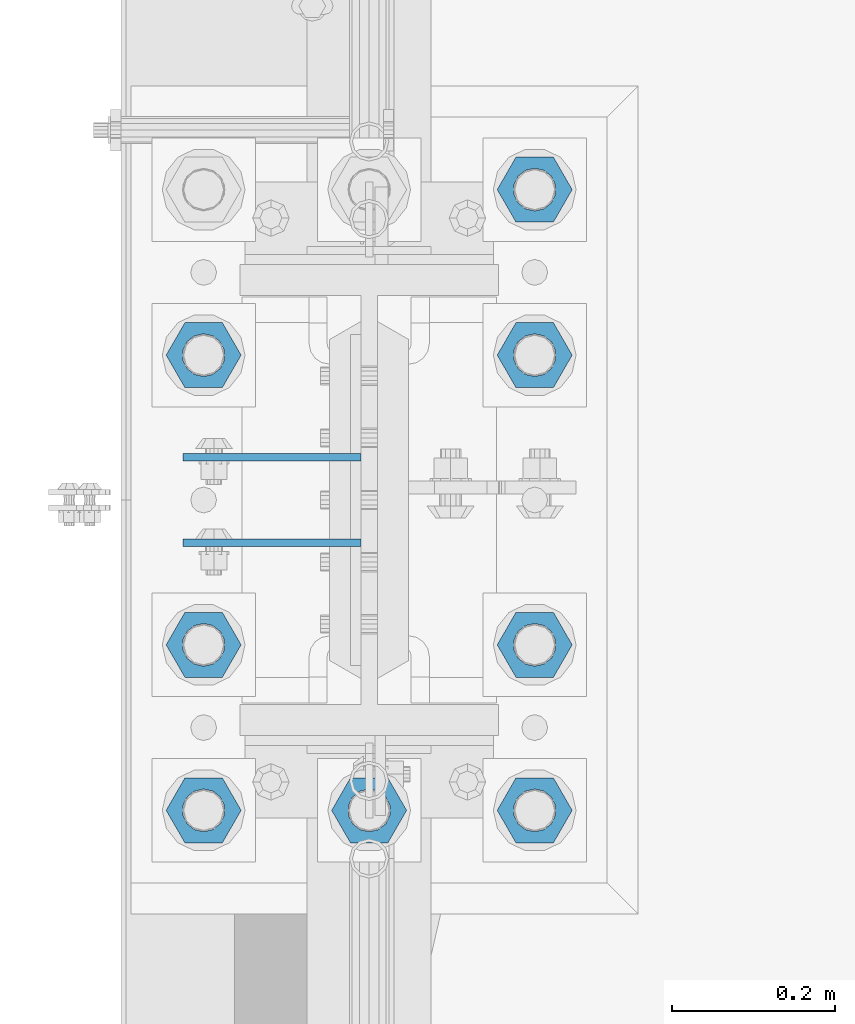
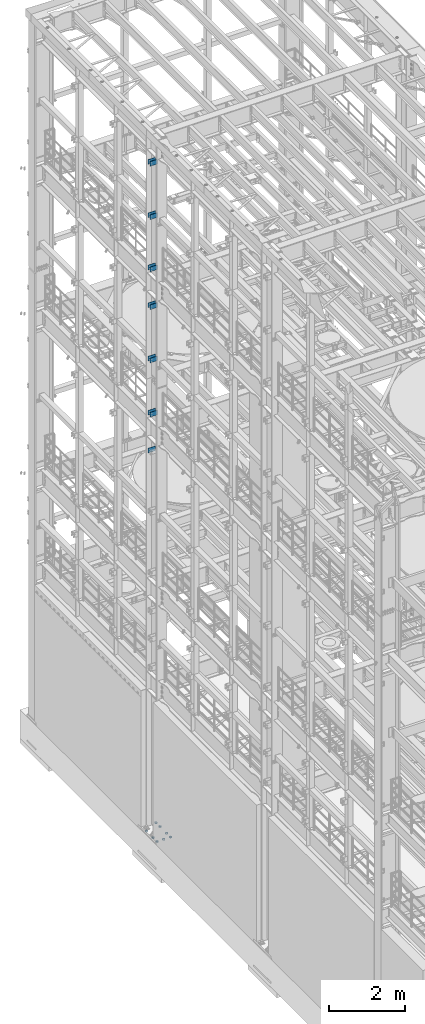
# One storey, part 1287 of 1876: 21 beams, 3 elements without a shape of their own.
"""IFC2X3 building model written with IfcOpenShell, lengths in millimetres."""

from ifc_helpers import new_model, si_unit, frame, origin_with_axes, place, context, subcontext, project, spatial, faceted_brep, material, type_object, element, aggregate, save


model = new_model("IFC2X3")

# Units and contexts
model_context = context("Model", 3, precision=1e-05, world=origin_with_axes())
body_context = subcontext(model_context, "Body", "Model", "MODEL_VIEW")
ifc_project = project(units=[si_unit("LENGTHUNIT", "METRE", prefix="MILLI"), si_unit("AREAUNIT", "SQUARE_METRE"), si_unit("VOLUMEUNIT", "CUBIC_METRE"), si_unit("MASSUNIT", "GRAM", prefix="KILO"), si_unit("TIMEUNIT", "SECOND"), si_unit("PLANEANGLEUNIT", "RADIAN"), si_unit("SOLIDANGLEUNIT", "STERADIAN"), si_unit("THERMODYNAMICTEMPERATUREUNIT", "DEGREE_CELSIUS"), si_unit("LUMINOUSINTENSITYUNIT", "LUMEN")], contexts=[model_context])

# Site, building, storey
site_placement = place(None, origin_with_axes())
site = spatial("IfcSite", under=ifc_project, at=site_placement, CompositionType="ELEMENT")
building_placement = place(site_placement, origin_with_axes())
building = spatial("IfcBuilding", under=site, at=building_placement, Name="Undefined", CompositionType="ELEMENT")
storey_placement = place(building_placement, origin_with_axes())
storey = spatial("IfcBuildingStorey", under=building, at=storey_placement, Name="Undefined", CompositionType="ELEMENT", Elevation=0.0)

# Assembly, beams
assembly_1_placement = place(storey_placement, origin_with_axes())
assembly_1 = element("IfcElementAssembly", 1, at=assembly_1_placement, inside=storey, Name="COLUMN", AssemblyPlace="NOTDEFINED", PredefinedType="RIGID_FRAME")
ifc_material_1 = material(Name="STEEL/A36")
beam_type_1 = type_object("IfcBeamType", PredefinedType="NOTDEFINED")
beam_1_placement = place(assembly_1_placement, frame((-10.31875, 7672.38750076294, 21678.9), z_axis=(0.0, 0.0, -1.0), x_axis=(-1.0, 0.0, 0.0)))
beam_1 = element("IfcBeam", 2, at=beam_1_placement, type_object=beam_type_1, material=ifc_material_1, Name="PLATE", context=body_context, shape_type="Brep", body=[
    faceted_brep([(0.0, 4.76249999999982, -76.1999999999998), (3.63797880709171e-12, 4.76249999999982, 76.1999969482422), (218.28125, 4.76250000000005, 76.2000000000007), (218.28125, 4.76250000000005, -76.2000000000007), (3.63797880709171e-12, -4.76249999999982, 76.1999969482422), (218.28125, -4.76250000000005, 76.2000000000007), (0.0, -4.76249999999982, -76.1999999999998), (218.28125, -4.76250000000005, -76.2000000000007)], [[[0, 1, 2, 3]], [[1, 4, 5, 2]], [[4, 6, 7, 5]], [[6, 0, 3, 7]], [[5, 7, 3, 2]], [[6, 4, 1, 0]]]),
])
beam_2_placement = place(assembly_1_placement, frame((-10.31875, 7567.61250076294, 21678.9), z_axis=(0.0, 0.0, -1.0), x_axis=(-1.0, 0.0, 0.0)))
beam_2 = element("IfcBeam", 3, at=beam_2_placement, type_object=beam_type_1, material=ifc_material_1, Name="PLATE", context=body_context, shape_type="Brep", body=[
    faceted_brep([(0.0, 4.76249999999982, -76.1999999999998), (3.63797880709171e-12, 4.76249999999982, 76.1999969482422), (218.28125, 4.76250000000005, 76.2000000000007), (218.28125, 4.76250000000005, -76.2000000000007), (3.63797880709171e-12, -4.76249999999982, 76.1999969482422), (218.28125, -4.76250000000005, 76.2000000000007), (0.0, -4.76249999999982, -76.1999999999998), (218.28125, -4.76250000000005, -76.2000000000007)], [[[0, 1, 2, 3]], [[1, 4, 5, 2]], [[4, 6, 7, 5]], [[6, 0, 3, 7]], [[5, 7, 3, 2]], [[6, 4, 1, 0]]]),
])
beam_3_placement = place(assembly_1_placement, frame((-10.31875, 7672.38750076294, 19958.05), z_axis=(0.0, 0.0, -1.0), x_axis=(-1.0, 0.0, 0.0)))
beam_3 = element("IfcBeam", 4, at=beam_3_placement, type_object=beam_type_1, material=ifc_material_1, Name="PLATE", context=body_context, shape_type="Brep", body=[
    faceted_brep([(0.0, 4.76249999999982, -76.1999999999998), (3.63797880709171e-12, 4.76249999999982, 76.1999969482422), (218.28125, 4.76250000000005, 76.2000000000007), (218.28125, 4.76250000000005, -76.2000000000007), (3.63797880709171e-12, -4.76249999999982, 76.1999969482422), (218.28125, -4.76250000000005, 76.2000000000007), (0.0, -4.76249999999982, -76.1999999999998), (218.28125, -4.76250000000005, -76.2000000000007)], [[[0, 1, 2, 3]], [[1, 4, 5, 2]], [[4, 6, 7, 5]], [[6, 0, 3, 7]], [[5, 7, 3, 2]], [[6, 4, 1, 0]]]),
])
beam_4_placement = place(assembly_1_placement, frame((-10.31875, 7567.61250076294, 19958.05), z_axis=(0.0, 0.0, -1.0), x_axis=(-1.0, 0.0, 0.0)))
beam_4 = element("IfcBeam", 5, at=beam_4_placement, type_object=beam_type_1, material=ifc_material_1, Name="PLATE", context=body_context, shape_type="Brep", body=[
    faceted_brep([(0.0, 4.76249999999982, -76.1999999999998), (3.63797880709171e-12, 4.76249999999982, 76.1999969482422), (218.28125, 4.76250000000005, 76.2000000000007), (218.28125, 4.76250000000005, -76.2000000000007), (3.63797880709171e-12, -4.76249999999982, 76.1999969482422), (218.28125, -4.76250000000005, 76.2000000000007), (0.0, -4.76249999999982, -76.1999999999998), (218.28125, -4.76250000000005, -76.2000000000007)], [[[0, 1, 2, 3]], [[1, 4, 5, 2]], [[4, 6, 7, 5]], [[6, 0, 3, 7]], [[5, 7, 3, 2]], [[6, 4, 1, 0]]]),
])
beam_5_placement = place(assembly_1_placement, frame((-10.31875, 7672.38750076294, 18275.3), z_axis=(0.0, 0.0, -1.0), x_axis=(-1.0, 0.0, 0.0)))
beam_5 = element("IfcBeam", 6, at=beam_5_placement, type_object=beam_type_1, material=ifc_material_1, Name="PLATE", context=body_context, shape_type="Brep", body=[
    faceted_brep([(0.0, 4.76249999999982, -76.1999999999998), (3.63797880709171e-12, 4.76249999999982, 76.1999969482422), (218.28125, 4.76250000000005, 76.2000000000007), (218.28125, 4.76250000000005, -76.2000000000007), (3.63797880709171e-12, -4.76249999999982, 76.1999969482422), (218.28125, -4.76250000000005, 76.2000000000007), (0.0, -4.76249999999982, -76.1999999999998), (218.28125, -4.76250000000005, -76.2000000000007)], [[[0, 1, 2, 3]], [[1, 4, 5, 2]], [[4, 6, 7, 5]], [[6, 0, 3, 7]], [[5, 7, 3, 2]], [[6, 4, 1, 0]]]),
])
beam_6_placement = place(assembly_1_placement, frame((-10.31875, 7567.61250076294, 18275.3), z_axis=(0.0, 0.0, -1.0), x_axis=(-1.0, 0.0, 0.0)))
beam_6 = element("IfcBeam", 7, at=beam_6_placement, type_object=beam_type_1, material=ifc_material_1, Name="PLATE", context=body_context, shape_type="Brep", body=[
    faceted_brep([(0.0, 4.76249999999982, -76.1999999999998), (3.63797880709171e-12, 4.76249999999982, 76.1999969482422), (218.28125, 4.76250000000005, 76.2000000000007), (218.28125, 4.76250000000005, -76.2000000000007), (3.63797880709171e-12, -4.76249999999982, 76.1999969482422), (218.28125, -4.76250000000005, 76.2000000000007), (0.0, -4.76249999999982, -76.1999999999998), (218.28125, -4.76250000000005, -76.2000000000007)], [[[0, 1, 2, 3]], [[1, 4, 5, 2]], [[4, 6, 7, 5]], [[6, 0, 3, 7]], [[5, 7, 3, 2]], [[6, 4, 1, 0]]]),
])
beam_7_placement = place(assembly_1_placement, frame((-10.31875, 7672.38750076294, 17056.1), z_axis=(0.0, 0.0, -1.0), x_axis=(-1.0, 0.0, 0.0)))
beam_7 = element("IfcBeam", 8, at=beam_7_placement, type_object=beam_type_1, material=ifc_material_1, Name="PLATE", context=body_context, shape_type="Brep", body=[
    faceted_brep([(0.0, 4.76249999999982, -76.1999999999998), (3.63797880709171e-12, 4.76249999999982, 76.1999969482422), (218.28125, 4.76250000000005, 76.2000000000007), (218.28125, 4.76250000000005, -76.2000000000007), (3.63797880709171e-12, -4.76249999999982, 76.1999969482422), (218.28125, -4.76250000000005, 76.2000000000007), (0.0, -4.76249999999982, -76.1999999999998), (218.28125, -4.76250000000005, -76.2000000000007)], [[[0, 1, 2, 3]], [[1, 4, 5, 2]], [[4, 6, 7, 5]], [[6, 0, 3, 7]], [[5, 7, 3, 2]], [[6, 4, 1, 0]]]),
])
beam_8_placement = place(assembly_1_placement, frame((-10.31875, 7567.61250076294, 17056.1), z_axis=(0.0, 0.0, -1.0), x_axis=(-1.0, 0.0, 0.0)))
beam_8 = element("IfcBeam", 9, at=beam_8_placement, type_object=beam_type_1, material=ifc_material_1, Name="PLATE", context=body_context, shape_type="Brep", body=[
    faceted_brep([(0.0, 4.76249999999982, -76.1999999999998), (3.63797880709171e-12, 4.76249999999982, 76.1999969482422), (218.28125, 4.76250000000005, 76.2000000000007), (218.28125, 4.76250000000005, -76.2000000000007), (3.63797880709171e-12, -4.76249999999982, 76.1999969482422), (218.28125, -4.76250000000005, 76.2000000000007), (0.0, -4.76249999999982, -76.1999999999998), (218.28125, -4.76250000000005, -76.2000000000007)], [[[0, 1, 2, 3]], [[1, 4, 5, 2]], [[4, 6, 7, 5]], [[6, 0, 3, 7]], [[5, 7, 3, 2]], [[6, 4, 1, 0]]]),
])
beam_9_placement = place(assembly_1_placement, frame((-10.31875, 7672.38750076294, 15335.25), z_axis=(0.0, 0.0, -1.0), x_axis=(-1.0, 0.0, 0.0)))
beam_9 = element("IfcBeam", 10, at=beam_9_placement, type_object=beam_type_1, material=ifc_material_1, Name="PLATE", context=body_context, shape_type="Brep", body=[
    faceted_brep([(0.0, 4.76249999999982, -76.1999999999998), (3.63797880709171e-12, 4.76249999999982, 76.1999969482422), (218.28125, 4.76250000000005, 76.2000000000007), (218.28125, 4.76250000000005, -76.2000000000007), (3.63797880709171e-12, -4.76249999999982, 76.1999969482422), (218.28125, -4.76250000000005, 76.2000000000007), (0.0, -4.76249999999982, -76.1999999999998), (218.28125, -4.76250000000005, -76.2000000000007)], [[[0, 1, 2, 3]], [[1, 4, 5, 2]], [[4, 6, 7, 5]], [[6, 0, 3, 7]], [[5, 7, 3, 2]], [[6, 4, 1, 0]]]),
])
beam_10_placement = place(assembly_1_placement, frame((-10.31875, 7567.61250076294, 15335.25), z_axis=(0.0, 0.0, -1.0), x_axis=(-1.0, 0.0, 0.0)))
beam_10 = element("IfcBeam", 11, at=beam_10_placement, type_object=beam_type_1, material=ifc_material_1, Name="PLATE", context=body_context, shape_type="Brep", body=[
    faceted_brep([(0.0, 4.76249999999982, -76.1999999999998), (3.63797880709171e-12, 4.76249999999982, 76.1999969482422), (218.28125, 4.76250000000005, 76.2000000000007), (218.28125, 4.76250000000005, -76.2000000000007), (3.63797880709171e-12, -4.76249999999982, 76.1999969482422), (218.28125, -4.76250000000005, 76.2000000000007), (0.0, -4.76249999999982, -76.1999999999998), (218.28125, -4.76250000000005, -76.2000000000007)], [[[0, 1, 2, 3]], [[1, 4, 5, 2]], [[4, 6, 7, 5]], [[6, 0, 3, 7]], [[5, 7, 3, 2]], [[6, 4, 1, 0]]]),
])
aggregate(assembly_1, [beam_1, beam_2, beam_3, beam_4, beam_5, beam_6, beam_7, beam_8, beam_9, beam_10])

assembly_2_placement = place(storey_placement, origin_with_axes())
assembly_2 = element("IfcElementAssembly", 12, at=assembly_2_placement, inside=storey, Name="COLUMN", AssemblyPlace="NOTDEFINED", PredefinedType="RIGID_FRAME")
beam_11_placement = place(assembly_2_placement, frame((-10.31875, 7672.38750076294, 13589.0), z_axis=(0.0, 0.0, -1.0), x_axis=(-1.0, 0.0, 0.0)))
beam_11 = element("IfcBeam", 13, at=beam_11_placement, type_object=beam_type_1, material=ifc_material_1, Name="PLATE", context=body_context, shape_type="Brep", body=[
    faceted_brep([(0.0, 4.76249999999982, -76.1999999999998), (3.63797880709171e-12, 4.76249999999982, 76.1999969482422), (218.28125, 4.76250000000005, 76.2000000000007), (218.28125, 4.76250000000005, -76.2000000000007), (3.63797880709171e-12, -4.76249999999982, 76.1999969482422), (218.28125, -4.76250000000005, 76.2000000000007), (0.0, -4.76249999999982, -76.1999999999998), (218.28125, -4.76250000000005, -76.2000000000007)], [[[0, 1, 2, 3]], [[1, 4, 5, 2]], [[4, 6, 7, 5]], [[6, 0, 3, 7]], [[5, 7, 3, 2]], [[6, 4, 1, 0]]]),
])
beam_12_placement = place(assembly_2_placement, frame((-10.31875, 7567.61250076294, 13589.0), z_axis=(0.0, 0.0, -1.0), x_axis=(-1.0, 0.0, 0.0)))
beam_12 = element("IfcBeam", 14, at=beam_12_placement, type_object=beam_type_1, material=ifc_material_1, Name="PLATE", context=body_context, shape_type="Brep", body=[
    faceted_brep([(0.0, 4.76249999999982, -76.1999999999998), (3.63797880709171e-12, 4.76249999999982, 76.1999969482422), (218.28125, 4.76250000000005, 76.2000000000007), (218.28125, 4.76250000000005, -76.2000000000007), (3.63797880709171e-12, -4.76249999999982, 76.1999969482422), (218.28125, -4.76250000000005, 76.2000000000007), (0.0, -4.76249999999982, -76.1999999999998), (218.28125, -4.76250000000005, -76.2000000000007)], [[[0, 1, 2, 3]], [[1, 4, 5, 2]], [[4, 6, 7, 5]], [[6, 0, 3, 7]], [[5, 7, 3, 2]], [[6, 4, 1, 0]]]),
])
beam_13_placement = place(assembly_2_placement, frame((-10.31875, 7672.38750076294, 12369.8), z_axis=(0.0, 0.0, -1.0), x_axis=(-1.0, 0.0, 0.0)))
beam_13 = element("IfcBeam", 15, at=beam_13_placement, type_object=beam_type_1, material=ifc_material_1, Name="PLATE", context=body_context, shape_type="Brep", body=[
    faceted_brep([(0.0, 4.76249999999982, -76.1999999999998), (3.63797880709171e-12, 4.76249999999982, 76.1999969482422), (218.28125, 4.76250000000005, 76.2000000000007), (218.28125, 4.76250000000005, -76.2000000000007), (3.63797880709171e-12, -4.76249999999982, 76.1999969482422), (218.28125, -4.76250000000005, 76.2000000000007), (0.0, -4.76249999999982, -76.1999999999998), (218.28125, -4.76250000000005, -76.2000000000007)], [[[0, 1, 2, 3]], [[1, 4, 5, 2]], [[4, 6, 7, 5]], [[6, 0, 3, 7]], [[5, 7, 3, 2]], [[6, 4, 1, 0]]]),
])
aggregate(assembly_2, [beam_11, beam_12, beam_13])

assembly_3_placement = place(storey_placement, origin_with_axes())
assembly_3 = element("IfcElementAssembly", 16, at=assembly_3_placement, inside=storey, Name="TEMPLATE", AssemblyPlace="NOTDEFINED", PredefinedType="RIGID_FRAME")
ifc_material_2 = material(Name="STEEL/A563")
beam_type_2 = type_object("IfcBeamType", Name="2_DIA. HALF_NUT", PredefinedType="NOTDEFINED")
beam_14_placement = place(assembly_3_placement, frame((-203.2, 7797.79999847412, 33.3375), z_axis=(0.0, -1.0, 0.0), x_axis=(0.0, 0.0, -1.0)))
beam_14 = element("IfcBeam", 17, at=beam_14_placement, type_object=beam_type_2, material=ifc_material_2, Name="NUT", ObjectType="2_DIA. HALF_NUT", context=body_context, shape_type="Brep", body=[
    faceted_brep([(0.0, -46.0369987487793, 9.09494701772928e-13), (0.0, -23.0184993743896, -39.869213104248), (25.4, -23.0184993743896, -39.869213104248), (25.4, -46.0369987487793, 9.09494701772928e-13), (0.0, 23.0184993743896, -39.869213104248), (25.4, 23.0184993743896, -39.869213104248), (0.0, 46.0369987487793, -9.09494701772928e-13), (25.4, 46.0369987487793, -9.09494701772928e-13), (0.0, 23.0184993743896, 39.869213104248), (25.4, 23.0184993743896, 39.869213104248), (0.0, -23.0184993743896, 39.869213104248), (25.4, -23.0184993743896, 39.869213104248), (0.0, 0.0, 26.1940002441406), (0.0, 11.3650617044514, 23.5999013092769), (25.4, 11.3650617044514, 23.5999013092769), (25.4, 0.0, 26.1940002441406), (0.0, 20.4791109456437, 16.3316083006703), (25.4, 20.4791109456437, 16.3316083006703), (0.0, 25.5370200498346, 5.82867859874477), (25.4, 25.5370200498346, 5.82867859874477), (0.0, 25.5370200498346, -5.82867859874477), (25.4, 25.5370200498346, -5.82867859874477), (0.0, 20.4791109456437, -16.3316083006703), (25.4, 20.4791109456437, -16.3316083006703), (0.0, 11.3650617044514, -23.5999013092769), (25.4, 11.3650617044514, -23.5999013092769), (0.0, 0.0, -26.1940002441406), (25.4, 0.0, -26.1940002441406), (0.0, -11.3650617044514, -23.5999013092769), (25.4, -11.3650617044514, -23.5999013092769), (0.0, -20.4791109456437, -16.3316083006703), (25.4, -20.4791109456437, -16.3316083006703), (0.0, -25.5370200498346, -5.82867859874477), (25.4, -25.5370200498346, -5.82867859874477), (0.0, -25.5370200498346, 5.82867859874477), (25.4, -25.5370200498346, 5.82867859874477), (0.0, -20.4791109456437, 16.3316083006703), (25.4, -20.4791109456437, 16.3316083006703), (0.0, -11.3650617044514, 23.5999013092769), (25.4, -11.3650617044514, 23.5999013092769)], [[[0, 1, 2, 3]], [[1, 4, 5, 2]], [[4, 6, 7, 5]], [[6, 8, 9, 7]], [[8, 10, 11, 9]], [[10, 0, 3, 11]], [[12, 13, 14, 15]], [[13, 16, 17, 14]], [[16, 18, 19, 17]], [[18, 20, 21, 19]], [[20, 22, 23, 21]], [[22, 24, 25, 23]], [[24, 26, 27, 25]], [[26, 28, 29, 27]], [[28, 30, 31, 29]], [[30, 32, 33, 31]], [[32, 34, 35, 33]], [[34, 36, 37, 35]], [[36, 38, 39, 37]], [[38, 12, 15, 39]], [[5, 7, 9, 11, 3, 2], [17, 19, 21, 23, 25, 27, 29, 31, 33, 35, 37, 39, 15, 14]], [[10, 8, 6, 4, 1, 0], [38, 36, 34, 32, 30, 28, 26, 24, 22, 20, 18, 16, 13, 12]]]),
])
beam_15_placement = place(assembly_3_placement, frame((203.2, 8001.00000152588, 33.3375), z_axis=(0.0, 1.0, 0.0), x_axis=(0.0, 0.0, -1.0)))
beam_15 = element("IfcBeam", 18, at=beam_15_placement, type_object=beam_type_2, material=ifc_material_2, Name="NUT", ObjectType="2_DIA. HALF_NUT", context=body_context, shape_type="Brep", body=[
    faceted_brep([(0.0, -46.0369987487793, 9.09494701772928e-13), (0.0, -23.0184993743896, -39.869213104248), (25.4, -23.0184993743896, -39.869213104248), (25.4, -46.0369987487793, 9.09494701772928e-13), (0.0, 23.0184993743896, -39.869213104248), (25.4, 23.0184993743896, -39.869213104248), (0.0, 46.0369987487793, -9.09494701772928e-13), (25.4, 46.0369987487793, -9.09494701772928e-13), (0.0, 23.0184993743896, 39.869213104248), (25.4, 23.0184993743896, 39.869213104248), (0.0, -23.0184993743896, 39.869213104248), (25.4, -23.0184993743896, 39.869213104248), (0.0, 0.0, 26.1940002441406), (0.0, 11.3650617044514, 23.5999013092769), (25.4, 11.3650617044514, 23.5999013092769), (25.4, 0.0, 26.1940002441406), (0.0, 20.4791109456437, 16.3316083006703), (25.4, 20.4791109456437, 16.3316083006703), (0.0, 25.5370200498346, 5.82867859874477), (25.4, 25.5370200498346, 5.82867859874477), (0.0, 25.5370200498346, -5.82867859874477), (25.4, 25.5370200498346, -5.82867859874477), (0.0, 20.4791109456437, -16.3316083006703), (25.4, 20.4791109456437, -16.3316083006703), (0.0, 11.3650617044514, -23.5999013092769), (25.4, 11.3650617044514, -23.5999013092769), (0.0, 0.0, -26.1940002441406), (25.4, 0.0, -26.1940002441406), (0.0, -11.3650617044514, -23.5999013092769), (25.4, -11.3650617044514, -23.5999013092769), (0.0, -20.4791109456437, -16.3316083006703), (25.4, -20.4791109456437, -16.3316083006703), (0.0, -25.5370200498346, -5.82867859874477), (25.4, -25.5370200498346, -5.82867859874477), (0.0, -25.5370200498346, 5.82867859874477), (25.4, -25.5370200498346, 5.82867859874477), (0.0, -20.4791109456437, 16.3316083006703), (25.4, -20.4791109456437, 16.3316083006703), (0.0, -11.3650617044514, 23.5999013092769), (25.4, -11.3650617044514, 23.5999013092769)], [[[0, 1, 2, 3]], [[1, 4, 5, 2]], [[4, 6, 7, 5]], [[6, 8, 9, 7]], [[8, 10, 11, 9]], [[10, 0, 3, 11]], [[12, 13, 14, 15]], [[13, 16, 17, 14]], [[16, 18, 19, 17]], [[18, 20, 21, 19]], [[20, 22, 23, 21]], [[22, 24, 25, 23]], [[24, 26, 27, 25]], [[26, 28, 29, 27]], [[28, 30, 31, 29]], [[30, 32, 33, 31]], [[32, 34, 35, 33]], [[34, 36, 37, 35]], [[36, 38, 39, 37]], [[38, 12, 15, 39]], [[5, 7, 9, 11, 3, 2], [17, 19, 21, 23, 25, 27, 29, 31, 33, 35, 37, 39, 15, 14]], [[10, 8, 6, 4, 1, 0], [38, 36, 34, 32, 30, 28, 26, 24, 22, 20, 18, 16, 13, 12]]]),
])
beam_16_placement = place(assembly_3_placement, frame((203.2, 7797.80000152588, 33.3375), z_axis=(0.0, 1.0, 0.0), x_axis=(0.0, 0.0, -1.0)))
beam_16 = element("IfcBeam", 19, at=beam_16_placement, type_object=beam_type_2, material=ifc_material_2, Name="NUT", ObjectType="2_DIA. HALF_NUT", context=body_context, shape_type="Brep", body=[
    faceted_brep([(0.0, -46.0369987487793, 9.09494701772928e-13), (0.0, -23.0184993743896, -39.869213104248), (25.4, -23.0184993743896, -39.869213104248), (25.4, -46.0369987487793, 9.09494701772928e-13), (0.0, 23.0184993743896, -39.869213104248), (25.4, 23.0184993743896, -39.869213104248), (0.0, 46.0369987487793, -9.09494701772928e-13), (25.4, 46.0369987487793, -9.09494701772928e-13), (0.0, 23.0184993743896, 39.869213104248), (25.4, 23.0184993743896, 39.869213104248), (0.0, -23.0184993743896, 39.869213104248), (25.4, -23.0184993743896, 39.869213104248), (0.0, 0.0, 26.1940002441406), (0.0, 11.3650617044514, 23.5999013092769), (25.4, 11.3650617044514, 23.5999013092769), (25.4, 0.0, 26.1940002441406), (0.0, 20.4791109456437, 16.3316083006703), (25.4, 20.4791109456437, 16.3316083006703), (0.0, 25.5370200498346, 5.82867859874477), (25.4, 25.5370200498346, 5.82867859874477), (0.0, 25.5370200498346, -5.82867859874477), (25.4, 25.5370200498346, -5.82867859874477), (0.0, 20.4791109456437, -16.3316083006703), (25.4, 20.4791109456437, -16.3316083006703), (0.0, 11.3650617044514, -23.5999013092769), (25.4, 11.3650617044514, -23.5999013092769), (0.0, 0.0, -26.1940002441406), (25.4, 0.0, -26.1940002441406), (0.0, -11.3650617044514, -23.5999013092769), (25.4, -11.3650617044514, -23.5999013092769), (0.0, -20.4791109456437, -16.3316083006703), (25.4, -20.4791109456437, -16.3316083006703), (0.0, -25.5370200498346, -5.82867859874477), (25.4, -25.5370200498346, -5.82867859874477), (0.0, -25.5370200498346, 5.82867859874477), (25.4, -25.5370200498346, 5.82867859874477), (0.0, -20.4791109456437, 16.3316083006703), (25.4, -20.4791109456437, 16.3316083006703), (0.0, -11.3650617044514, 23.5999013092769), (25.4, -11.3650617044514, 23.5999013092769)], [[[0, 1, 2, 3]], [[1, 4, 5, 2]], [[4, 6, 7, 5]], [[6, 8, 9, 7]], [[8, 10, 11, 9]], [[10, 0, 3, 11]], [[12, 13, 14, 15]], [[13, 16, 17, 14]], [[16, 18, 19, 17]], [[18, 20, 21, 19]], [[20, 22, 23, 21]], [[22, 24, 25, 23]], [[24, 26, 27, 25]], [[26, 28, 29, 27]], [[28, 30, 31, 29]], [[30, 32, 33, 31]], [[32, 34, 35, 33]], [[34, 36, 37, 35]], [[36, 38, 39, 37]], [[38, 12, 15, 39]], [[5, 7, 9, 11, 3, 2], [17, 19, 21, 23, 25, 27, 29, 31, 33, 35, 37, 39, 15, 14]], [[10, 8, 6, 4, 1, 0], [38, 36, 34, 32, 30, 28, 26, 24, 22, 20, 18, 16, 13, 12]]]),
])
beam_17_placement = place(assembly_3_placement, frame((-203.2, 7442.19999847412, 33.3375), z_axis=(0.0, -1.0, 0.0), x_axis=(0.0, 0.0, -1.0)))
beam_17 = element("IfcBeam", 20, at=beam_17_placement, type_object=beam_type_2, material=ifc_material_2, Name="NUT", ObjectType="2_DIA. HALF_NUT", context=body_context, shape_type="Brep", body=[
    faceted_brep([(0.0, -46.0369987487793, 9.09494701772928e-13), (0.0, -23.0184993743896, -39.869213104248), (25.4, -23.0184993743896, -39.869213104248), (25.4, -46.0369987487793, 9.09494701772928e-13), (0.0, 23.0184993743896, -39.869213104248), (25.4, 23.0184993743896, -39.869213104248), (0.0, 46.0369987487793, -9.09494701772928e-13), (25.4, 46.0369987487793, -9.09494701772928e-13), (0.0, 23.0184993743896, 39.869213104248), (25.4, 23.0184993743896, 39.869213104248), (0.0, -23.0184993743896, 39.869213104248), (25.4, -23.0184993743896, 39.869213104248), (0.0, 0.0, 26.1940002441406), (0.0, 11.3650617044514, 23.5999013092769), (25.4, 11.3650617044514, 23.5999013092769), (25.4, 0.0, 26.1940002441406), (0.0, 20.4791109456437, 16.3316083006703), (25.4, 20.4791109456437, 16.3316083006703), (0.0, 25.5370200498346, 5.82867859874477), (25.4, 25.5370200498346, 5.82867859874477), (0.0, 25.5370200498346, -5.82867859874477), (25.4, 25.5370200498346, -5.82867859874477), (0.0, 20.4791109456437, -16.3316083006703), (25.4, 20.4791109456437, -16.3316083006703), (0.0, 11.3650617044514, -23.5999013092769), (25.4, 11.3650617044514, -23.5999013092769), (0.0, 0.0, -26.1940002441406), (25.4, 0.0, -26.1940002441406), (0.0, -11.3650617044514, -23.5999013092769), (25.4, -11.3650617044514, -23.5999013092769), (0.0, -20.4791109456437, -16.3316083006703), (25.4, -20.4791109456437, -16.3316083006703), (0.0, -25.5370200498346, -5.82867859874477), (25.4, -25.5370200498346, -5.82867859874477), (0.0, -25.5370200498346, 5.82867859874477), (25.4, -25.5370200498346, 5.82867859874477), (0.0, -20.4791109456437, 16.3316083006703), (25.4, -20.4791109456437, 16.3316083006703), (0.0, -11.3650617044514, 23.5999013092769), (25.4, -11.3650617044514, 23.5999013092769)], [[[0, 1, 2, 3]], [[1, 4, 5, 2]], [[4, 6, 7, 5]], [[6, 8, 9, 7]], [[8, 10, 11, 9]], [[10, 0, 3, 11]], [[12, 13, 14, 15]], [[13, 16, 17, 14]], [[16, 18, 19, 17]], [[18, 20, 21, 19]], [[20, 22, 23, 21]], [[22, 24, 25, 23]], [[24, 26, 27, 25]], [[26, 28, 29, 27]], [[28, 30, 31, 29]], [[30, 32, 33, 31]], [[32, 34, 35, 33]], [[34, 36, 37, 35]], [[36, 38, 39, 37]], [[38, 12, 15, 39]], [[5, 7, 9, 11, 3, 2], [17, 19, 21, 23, 25, 27, 29, 31, 33, 35, 37, 39, 15, 14]], [[10, 8, 6, 4, 1, 0], [38, 36, 34, 32, 30, 28, 26, 24, 22, 20, 18, 16, 13, 12]]]),
])
beam_18_placement = place(assembly_3_placement, frame((203.2, 7442.20000152588, 33.3375), z_axis=(0.0, 1.0, 0.0), x_axis=(0.0, 0.0, -1.0)))
beam_18 = element("IfcBeam", 21, at=beam_18_placement, type_object=beam_type_2, material=ifc_material_2, Name="NUT", ObjectType="2_DIA. HALF_NUT", context=body_context, shape_type="Brep", body=[
    faceted_brep([(0.0, -46.0369987487793, 9.09494701772928e-13), (0.0, -23.0184993743896, -39.869213104248), (25.4, -23.0184993743896, -39.869213104248), (25.4, -46.0369987487793, 9.09494701772928e-13), (0.0, 23.0184993743896, -39.869213104248), (25.4, 23.0184993743896, -39.869213104248), (0.0, 46.0369987487793, -9.09494701772928e-13), (25.4, 46.0369987487793, -9.09494701772928e-13), (0.0, 23.0184993743896, 39.869213104248), (25.4, 23.0184993743896, 39.869213104248), (0.0, -23.0184993743896, 39.869213104248), (25.4, -23.0184993743896, 39.869213104248), (0.0, 0.0, 26.1940002441406), (0.0, 11.3650617044514, 23.5999013092769), (25.4, 11.3650617044514, 23.5999013092769), (25.4, 0.0, 26.1940002441406), (0.0, 20.4791109456437, 16.3316083006703), (25.4, 20.4791109456437, 16.3316083006703), (0.0, 25.5370200498346, 5.82867859874477), (25.4, 25.5370200498346, 5.82867859874477), (0.0, 25.5370200498346, -5.82867859874477), (25.4, 25.5370200498346, -5.82867859874477), (0.0, 20.4791109456437, -16.3316083006703), (25.4, 20.4791109456437, -16.3316083006703), (0.0, 11.3650617044514, -23.5999013092769), (25.4, 11.3650617044514, -23.5999013092769), (0.0, 0.0, -26.1940002441406), (25.4, 0.0, -26.1940002441406), (0.0, -11.3650617044514, -23.5999013092769), (25.4, -11.3650617044514, -23.5999013092769), (0.0, -20.4791109456437, -16.3316083006703), (25.4, -20.4791109456437, -16.3316083006703), (0.0, -25.5370200498346, -5.82867859874477), (25.4, -25.5370200498346, -5.82867859874477), (0.0, -25.5370200498346, 5.82867859874477), (25.4, -25.5370200498346, 5.82867859874477), (0.0, -20.4791109456437, 16.3316083006703), (25.4, -20.4791109456437, 16.3316083006703), (0.0, -11.3650617044514, 23.5999013092769), (25.4, -11.3650617044514, 23.5999013092769)], [[[0, 1, 2, 3]], [[1, 4, 5, 2]], [[4, 6, 7, 5]], [[6, 8, 9, 7]], [[8, 10, 11, 9]], [[10, 0, 3, 11]], [[12, 13, 14, 15]], [[13, 16, 17, 14]], [[16, 18, 19, 17]], [[18, 20, 21, 19]], [[20, 22, 23, 21]], [[22, 24, 25, 23]], [[24, 26, 27, 25]], [[26, 28, 29, 27]], [[28, 30, 31, 29]], [[30, 32, 33, 31]], [[32, 34, 35, 33]], [[34, 36, 37, 35]], [[36, 38, 39, 37]], [[38, 12, 15, 39]], [[5, 7, 9, 11, 3, 2], [17, 19, 21, 23, 25, 27, 29, 31, 33, 35, 37, 39, 15, 14]], [[10, 8, 6, 4, 1, 0], [38, 36, 34, 32, 30, 28, 26, 24, 22, 20, 18, 16, 13, 12]]]),
])
beam_19_placement = place(assembly_3_placement, frame((203.2, 7239.00000152588, 33.3375), z_axis=(0.0, 1.0, 0.0), x_axis=(0.0, 0.0, -1.0)))
beam_19 = element("IfcBeam", 22, at=beam_19_placement, type_object=beam_type_2, material=ifc_material_2, Name="NUT", ObjectType="2_DIA. HALF_NUT", context=body_context, shape_type="Brep", body=[
    faceted_brep([(0.0, -46.0369987487793, 9.09494701772928e-13), (0.0, -23.0184993743896, -39.869213104248), (25.4, -23.0184993743896, -39.869213104248), (25.4, -46.0369987487793, 9.09494701772928e-13), (0.0, 23.0184993743896, -39.869213104248), (25.4, 23.0184993743896, -39.869213104248), (0.0, 46.0369987487793, -9.09494701772928e-13), (25.4, 46.0369987487793, -9.09494701772928e-13), (0.0, 23.0184993743896, 39.869213104248), (25.4, 23.0184993743896, 39.869213104248), (0.0, -23.0184993743896, 39.869213104248), (25.4, -23.0184993743896, 39.869213104248), (0.0, 0.0, 26.1940002441406), (0.0, 11.3650617044514, 23.5999013092769), (25.4, 11.3650617044514, 23.5999013092769), (25.4, 0.0, 26.1940002441406), (0.0, 20.4791109456437, 16.3316083006703), (25.4, 20.4791109456437, 16.3316083006703), (0.0, 25.5370200498346, 5.82867859874477), (25.4, 25.5370200498346, 5.82867859874477), (0.0, 25.5370200498346, -5.82867859874477), (25.4, 25.5370200498346, -5.82867859874477), (0.0, 20.4791109456437, -16.3316083006703), (25.4, 20.4791109456437, -16.3316083006703), (0.0, 11.3650617044514, -23.5999013092769), (25.4, 11.3650617044514, -23.5999013092769), (0.0, 0.0, -26.1940002441406), (25.4, 0.0, -26.1940002441406), (0.0, -11.3650617044514, -23.5999013092769), (25.4, -11.3650617044514, -23.5999013092769), (0.0, -20.4791109456437, -16.3316083006703), (25.4, -20.4791109456437, -16.3316083006703), (0.0, -25.5370200498346, -5.82867859874477), (25.4, -25.5370200498346, -5.82867859874477), (0.0, -25.5370200498346, 5.82867859874477), (25.4, -25.5370200498346, 5.82867859874477), (0.0, -20.4791109456437, 16.3316083006703), (25.4, -20.4791109456437, 16.3316083006703), (0.0, -11.3650617044514, 23.5999013092769), (25.4, -11.3650617044514, 23.5999013092769)], [[[0, 1, 2, 3]], [[1, 4, 5, 2]], [[4, 6, 7, 5]], [[6, 8, 9, 7]], [[8, 10, 11, 9]], [[10, 0, 3, 11]], [[12, 13, 14, 15]], [[13, 16, 17, 14]], [[16, 18, 19, 17]], [[18, 20, 21, 19]], [[20, 22, 23, 21]], [[22, 24, 25, 23]], [[24, 26, 27, 25]], [[26, 28, 29, 27]], [[28, 30, 31, 29]], [[30, 32, 33, 31]], [[32, 34, 35, 33]], [[34, 36, 37, 35]], [[36, 38, 39, 37]], [[38, 12, 15, 39]], [[5, 7, 9, 11, 3, 2], [17, 19, 21, 23, 25, 27, 29, 31, 33, 35, 37, 39, 15, 14]], [[10, 8, 6, 4, 1, 0], [38, 36, 34, 32, 30, 28, 26, 24, 22, 20, 18, 16, 13, 12]]]),
])
beam_20_placement = place(assembly_3_placement, frame((0.0, 7238.99999847412, 33.3375), z_axis=(0.0, -1.0, 0.0), x_axis=(0.0, 0.0, -1.0)))
beam_20 = element("IfcBeam", 23, at=beam_20_placement, type_object=beam_type_2, material=ifc_material_2, Name="NUT", ObjectType="2_DIA. HALF_NUT", context=body_context, shape_type="Brep", body=[
    faceted_brep([(0.0, -46.0369987487793, 9.09494701772928e-13), (0.0, -23.0184993743896, -39.869213104248), (25.4, -23.0184993743896, -39.869213104248), (25.4, -46.0369987487793, 9.09494701772928e-13), (0.0, 23.0184993743896, -39.869213104248), (25.4, 23.0184993743896, -39.869213104248), (0.0, 46.0369987487793, -9.09494701772928e-13), (25.4, 46.0369987487793, -9.09494701772928e-13), (0.0, 23.0184993743896, 39.869213104248), (25.4, 23.0184993743896, 39.869213104248), (0.0, -23.0184993743896, 39.869213104248), (25.4, -23.0184993743896, 39.869213104248), (0.0, 0.0, 26.1940002441406), (0.0, 11.3650617044514, 23.5999013092769), (25.4, 11.3650617044514, 23.5999013092769), (25.4, 0.0, 26.1940002441406), (0.0, 20.4791109456437, 16.3316083006703), (25.4, 20.4791109456437, 16.3316083006703), (0.0, 25.5370200498346, 5.82867859874477), (25.4, 25.5370200498346, 5.82867859874477), (0.0, 25.5370200498346, -5.82867859874477), (25.4, 25.5370200498346, -5.82867859874477), (0.0, 20.4791109456437, -16.3316083006703), (25.4, 20.4791109456437, -16.3316083006703), (0.0, 11.3650617044514, -23.5999013092769), (25.4, 11.3650617044514, -23.5999013092769), (0.0, 0.0, -26.1940002441406), (25.4, 0.0, -26.1940002441406), (0.0, -11.3650617044514, -23.5999013092769), (25.4, -11.3650617044514, -23.5999013092769), (0.0, -20.4791109456437, -16.3316083006703), (25.4, -20.4791109456437, -16.3316083006703), (0.0, -25.5370200498346, -5.82867859874477), (25.4, -25.5370200498346, -5.82867859874477), (0.0, -25.5370200498346, 5.82867859874477), (25.4, -25.5370200498346, 5.82867859874477), (0.0, -20.4791109456437, 16.3316083006703), (25.4, -20.4791109456437, 16.3316083006703), (0.0, -11.3650617044514, 23.5999013092769), (25.4, -11.3650617044514, 23.5999013092769)], [[[0, 1, 2, 3]], [[1, 4, 5, 2]], [[4, 6, 7, 5]], [[6, 8, 9, 7]], [[8, 10, 11, 9]], [[10, 0, 3, 11]], [[12, 13, 14, 15]], [[13, 16, 17, 14]], [[16, 18, 19, 17]], [[18, 20, 21, 19]], [[20, 22, 23, 21]], [[22, 24, 25, 23]], [[24, 26, 27, 25]], [[26, 28, 29, 27]], [[28, 30, 31, 29]], [[30, 32, 33, 31]], [[32, 34, 35, 33]], [[34, 36, 37, 35]], [[36, 38, 39, 37]], [[38, 12, 15, 39]], [[5, 7, 9, 11, 3, 2], [17, 19, 21, 23, 25, 27, 29, 31, 33, 35, 37, 39, 15, 14]], [[10, 8, 6, 4, 1, 0], [38, 36, 34, 32, 30, 28, 26, 24, 22, 20, 18, 16, 13, 12]]]),
])
beam_21_placement = place(assembly_3_placement, frame((-203.2, 7238.99999847412, 33.3375), z_axis=(0.0, -1.0, 0.0), x_axis=(0.0, 0.0, -1.0)))
beam_21 = element("IfcBeam", 24, at=beam_21_placement, type_object=beam_type_2, material=ifc_material_2, Name="NUT", ObjectType="2_DIA. HALF_NUT", context=body_context, shape_type="Brep", body=[
    faceted_brep([(0.0, -46.0369987487793, 9.09494701772928e-13), (0.0, -23.0184993743896, -39.869213104248), (25.4, -23.0184993743896, -39.869213104248), (25.4, -46.0369987487793, 9.09494701772928e-13), (0.0, 23.0184993743896, -39.869213104248), (25.4, 23.0184993743896, -39.869213104248), (0.0, 46.0369987487793, -9.09494701772928e-13), (25.4, 46.0369987487793, -9.09494701772928e-13), (0.0, 23.0184993743896, 39.869213104248), (25.4, 23.0184993743896, 39.869213104248), (0.0, -23.0184993743896, 39.869213104248), (25.4, -23.0184993743896, 39.869213104248), (0.0, 0.0, 26.1940002441406), (0.0, 11.3650617044514, 23.5999013092769), (25.4, 11.3650617044514, 23.5999013092769), (25.4, 0.0, 26.1940002441406), (0.0, 20.4791109456437, 16.3316083006703), (25.4, 20.4791109456437, 16.3316083006703), (0.0, 25.5370200498346, 5.82867859874477), (25.4, 25.5370200498346, 5.82867859874477), (0.0, 25.5370200498346, -5.82867859874477), (25.4, 25.5370200498346, -5.82867859874477), (0.0, 20.4791109456437, -16.3316083006703), (25.4, 20.4791109456437, -16.3316083006703), (0.0, 11.3650617044514, -23.5999013092769), (25.4, 11.3650617044514, -23.5999013092769), (0.0, 0.0, -26.1940002441406), (25.4, 0.0, -26.1940002441406), (0.0, -11.3650617044514, -23.5999013092769), (25.4, -11.3650617044514, -23.5999013092769), (0.0, -20.4791109456437, -16.3316083006703), (25.4, -20.4791109456437, -16.3316083006703), (0.0, -25.5370200498346, -5.82867859874477), (25.4, -25.5370200498346, -5.82867859874477), (0.0, -25.5370200498346, 5.82867859874477), (25.4, -25.5370200498346, 5.82867859874477), (0.0, -20.4791109456437, 16.3316083006703), (25.4, -20.4791109456437, 16.3316083006703), (0.0, -11.3650617044514, 23.5999013092769), (25.4, -11.3650617044514, 23.5999013092769)], [[[0, 1, 2, 3]], [[1, 4, 5, 2]], [[4, 6, 7, 5]], [[6, 8, 9, 7]], [[8, 10, 11, 9]], [[10, 0, 3, 11]], [[12, 13, 14, 15]], [[13, 16, 17, 14]], [[16, 18, 19, 17]], [[18, 20, 21, 19]], [[20, 22, 23, 21]], [[22, 24, 25, 23]], [[24, 26, 27, 25]], [[26, 28, 29, 27]], [[28, 30, 31, 29]], [[30, 32, 33, 31]], [[32, 34, 35, 33]], [[34, 36, 37, 35]], [[36, 38, 39, 37]], [[38, 12, 15, 39]], [[5, 7, 9, 11, 3, 2], [17, 19, 21, 23, 25, 27, 29, 31, 33, 35, 37, 39, 15, 14]], [[10, 8, 6, 4, 1, 0], [38, 36, 34, 32, 30, 28, 26, 24, 22, 20, 18, 16, 13, 12]]]),
])
aggregate(assembly_3, [beam_14, beam_15, beam_16, beam_17, beam_18, beam_19, beam_20, beam_21])

save(model, "model.ifc")
